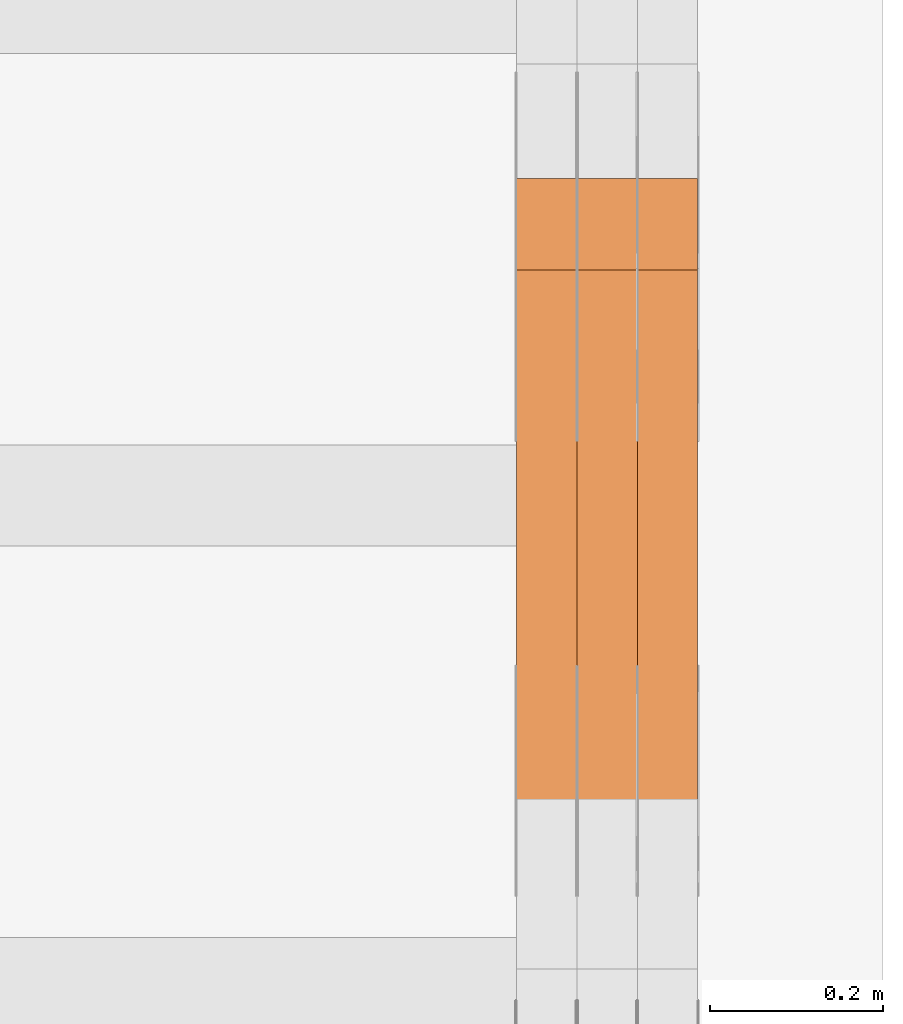
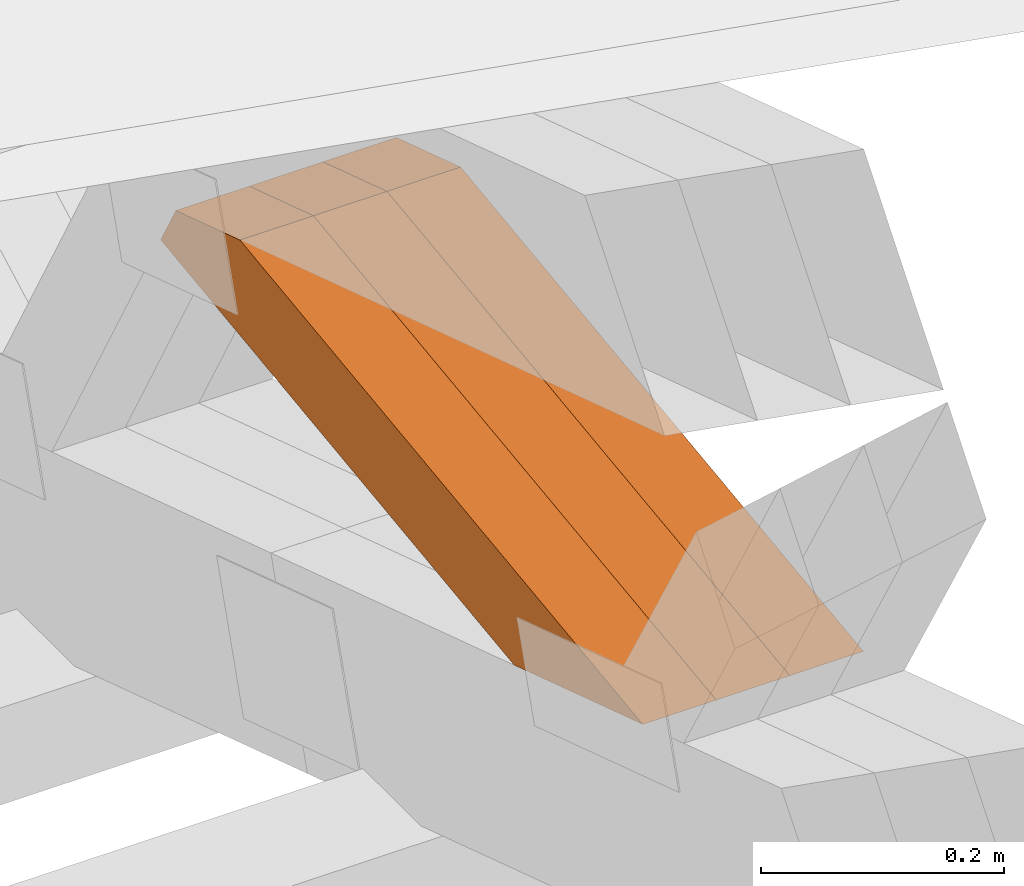
# One storey, part 330 of 385: 3 proxies.
"""IFC2X3 building model written with IfcOpenShell, lengths in millimetres."""

from ifc_helpers import new_model, entity, si_unit, converted_unit, derived_unit, direction, frame, origin, place, context, subcontext, project, spatial, polyline, outline, extrude, source, transform, mapped, material, type_object, type_shapes, element, save


model = new_model("IFC2X3")

# Units and contexts
model_context = context("Model", 3, precision=0.01, world=origin(), true_north=direction((6.12303176911189e-17, 1.0)))
body_context = subcontext(model_context, "Body", "Model", "MODEL_VIEW")
ifc_project = project(units=[si_unit("LENGTHUNIT", "METRE", prefix="MILLI"), si_unit("AREAUNIT", "SQUARE_METRE"), si_unit("VOLUMEUNIT", "CUBIC_METRE"), converted_unit("PLANEANGLEUNIT", "DEGREE", entity("IfcRatioMeasure", 0.0174532925199433), si_unit("PLANEANGLEUNIT", "RADIAN"), dimensions=[0, 0, 0, 0, 0, 0, 0]), si_unit("MASSUNIT", "GRAM", prefix="KILO"), derived_unit("MASSDENSITYUNIT", [(si_unit("MASSUNIT", "GRAM", prefix="KILO"), 1), (si_unit("LENGTHUNIT", "METRE"), -3)]), si_unit("TIMEUNIT", "SECOND"), si_unit("FREQUENCYUNIT", "HERTZ"), si_unit("THERMODYNAMICTEMPERATUREUNIT", "DEGREE_CELSIUS"), derived_unit("THERMALTRANSMITTANCEUNIT", [(si_unit("MASSUNIT", "GRAM", prefix="KILO"), 1), (si_unit("THERMODYNAMICTEMPERATUREUNIT", "KELVIN"), -1), (si_unit("TIMEUNIT", "SECOND"), -3)]), derived_unit("VOLUMETRICFLOWRATEUNIT", [(si_unit("LENGTHUNIT", "METRE"), 3), (si_unit("TIMEUNIT", "SECOND"), -1)]), si_unit("ELECTRICCURRENTUNIT", "AMPERE"), si_unit("ELECTRICVOLTAGEUNIT", "VOLT"), si_unit("POWERUNIT", "WATT"), si_unit("FORCEUNIT", "NEWTON", prefix="KILO"), si_unit("ILLUMINANCEUNIT", "LUX"), si_unit("LUMINOUSFLUXUNIT", "LUMEN"), si_unit("LUMINOUSINTENSITYUNIT", "CANDELA"), derived_unit("USERDEFINED", [(si_unit("MASSUNIT", "GRAM", prefix="KILO"), -1), (si_unit("LENGTHUNIT", "METRE"), -2), (si_unit("TIMEUNIT", "SECOND"), 3), (si_unit("LUMINOUSFLUXUNIT", "LUMEN"), 1)]), derived_unit("LINEARVELOCITYUNIT", [(si_unit("LENGTHUNIT", "METRE"), 1), (si_unit("TIMEUNIT", "SECOND"), -1)]), si_unit("PRESSUREUNIT", "PASCAL"), derived_unit("USERDEFINED", [(si_unit("LENGTHUNIT", "METRE"), -2), (si_unit("MASSUNIT", "GRAM", prefix="KILO"), 1), (si_unit("TIMEUNIT", "SECOND"), -2)])], contexts=[model_context])

# Site, building, storey
site_placement = place(None, origin())
site = spatial("IfcSite", under=ifc_project, at=site_placement, CompositionType="ELEMENT")
building_placement = place(site_placement, origin())
building = spatial("IfcBuilding", under=site, at=building_placement, CompositionType="ELEMENT")
storey_placement = place(building_placement, origin())
storey = spatial("IfcBuildingStorey", under=building, at=storey_placement, Name="Default", CompositionType="ELEMENT", Elevation=0.0)

# Proxies
ifc_material_1 = material(Name="IfcSurfaceStyle #601174")
building_element_proxy_type_1 = type_object("IfcBuildingElementProxyType", Name="T2-W6 601172", PredefinedType="NOTDEFINED", material=ifc_material_1)
shared_shape_1 = source(origin(), body_context, "Body", "SweptSolid", [
    extrude(outline(polyline([(-485.945461934772, -47.500204767976), (183.41906495488, -47.500204767976), (284.061400026172, 0.000179660053988773), (303.127757064591, 47.500114937949), (-284.66276011087, 47.500114937949), (-485.945461934772, -47.500204767976)])), frame((303.127970456024, 47.5001450766485, 0.0), z_axis=(0.0, 0.0, 1.0), x_axis=(-1.0, 0.0, 0.0)), (0.0, 0.0, 1.0), 70.0),
])
type_shapes(building_element_proxy_type_1, [shared_shape_1])
proxy_1_placement = place(building_placement, frame((49860.0, 19075.4826373647, 2770.72729201433), z_axis=(-1.0, 0.0, 0.0), x_axis=(0.0, -0.991969529622927, -0.126477082112413)))
element("IfcBuildingElementProxy", 1, at=proxy_1_placement, inside=storey, type_object=building_element_proxy_type_1, material=ifc_material_1, Name="T2-W6", context=body_context, shape_type="MappedRepresentation", body=[
    mapped(shared_shape_1, transform((0.0, 0.0, 0.0), scale=1.0)),
])
ifc_material_2 = material(Name="IfcSurfaceStyle #601108")
building_element_proxy_type_2 = type_object("IfcBuildingElementProxyType", Name="T2-W6 601106", PredefinedType="NOTDEFINED", material=ifc_material_2)
shared_shape_2 = source(origin(), body_context, "Body", "SweptSolid", [
    extrude(outline(polyline([(-485.945461934772, -47.500204767976), (183.41906495488, -47.500204767976), (284.061400026172, 0.000179660053988773), (303.127757064591, 47.500114937949), (-284.66276011087, 47.500114937949), (-485.945461934772, -47.500204767976)])), frame((303.127970456024, 47.5001450766485, 0.0), z_axis=(0.0, 0.0, 1.0), x_axis=(-1.0, 0.0, 0.0)), (0.0, 0.0, 1.0), 70.0),
])
type_shapes(building_element_proxy_type_2, [shared_shape_2])
proxy_2_placement = place(building_placement, frame((49790.0, 19075.4826373647, 2770.72729201433), z_axis=(-1.0, 0.0, 0.0), x_axis=(0.0, -0.991969529622927, -0.126477082112413)))
element("IfcBuildingElementProxy", 2, at=proxy_2_placement, inside=storey, type_object=building_element_proxy_type_2, material=ifc_material_2, Name="T2-W6", context=body_context, shape_type="MappedRepresentation", body=[
    mapped(shared_shape_2, transform((0.0, 0.0, 0.0), scale=1.0)),
])
ifc_material_3 = material(Name="IfcSurfaceStyle #601042")
building_element_proxy_type_3 = type_object("IfcBuildingElementProxyType", Name="T2-W6 601040", PredefinedType="NOTDEFINED", material=ifc_material_3)
shared_shape_3 = source(origin(), body_context, "Body", "SweptSolid", [
    extrude(outline(polyline([(-485.945461934772, -47.500204767976), (183.41906495488, -47.500204767976), (284.061400026172, 0.000179660053988773), (303.127757064591, 47.500114937949), (-284.66276011087, 47.500114937949), (-485.945461934772, -47.500204767976)])), frame((303.127970456024, 47.5001450766485, 0.0), z_axis=(0.0, 0.0, 1.0), x_axis=(-1.0, 0.0, 0.0)), (0.0, 0.0, 1.0), 70.0),
])
type_shapes(building_element_proxy_type_3, [shared_shape_3])
proxy_3_placement = place(building_placement, frame((49720.0, 19075.4826373647, 2770.72729201433), z_axis=(-1.0, 0.0, 0.0), x_axis=(0.0, -0.991969529622927, -0.126477082112413)))
element("IfcBuildingElementProxy", 3, at=proxy_3_placement, inside=storey, type_object=building_element_proxy_type_3, material=ifc_material_3, Name="T2-W6", context=body_context, shape_type="MappedRepresentation", body=[
    mapped(shared_shape_3, transform((0.0, 0.0, 0.0), scale=1.0)),
])

save(model, "model.ifc")
